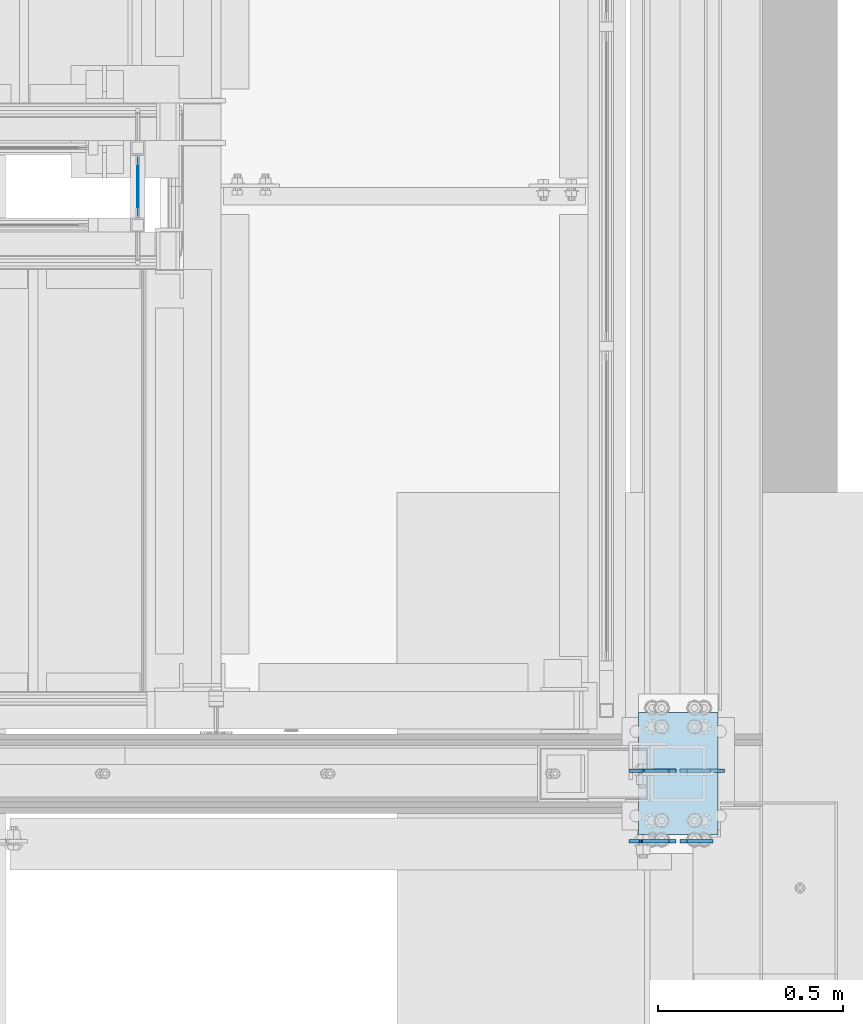
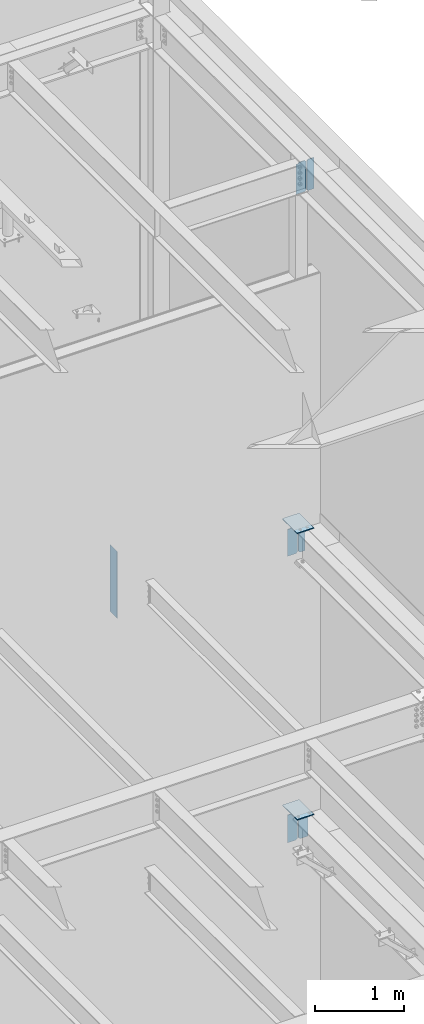
# One storey, part 1098 of 1179: 9 plates, 6 elements without a shape of their own.
"""IFC2X3 building model written with IfcOpenShell, lengths in millimetres."""

from ifc_helpers import new_model, si_unit, frame, origin_with_axes, place, context, subcontext, project, spatial, faceted_brep, material, type_object, element, aggregate, save


model = new_model("IFC2X3")

# Units and contexts
model_context = context("Model", 3, precision=1e-05, world=origin_with_axes())
body_context = subcontext(model_context, "Body", "Model", "MODEL_VIEW")
ifc_project = project(units=[si_unit("LENGTHUNIT", "METRE", prefix="MILLI"), si_unit("AREAUNIT", "SQUARE_METRE"), si_unit("VOLUMEUNIT", "CUBIC_METRE"), si_unit("MASSUNIT", "GRAM", prefix="KILO"), si_unit("TIMEUNIT", "SECOND"), si_unit("PLANEANGLEUNIT", "RADIAN"), si_unit("SOLIDANGLEUNIT", "STERADIAN"), si_unit("THERMODYNAMICTEMPERATUREUNIT", "DEGREE_CELSIUS"), si_unit("LUMINOUSINTENSITYUNIT", "LUMEN")], contexts=[model_context])

# Site, building, storey
site_placement = place(None, origin_with_axes())
site = spatial("IfcSite", under=ifc_project, at=site_placement, CompositionType="ELEMENT")
building_placement = place(site_placement, origin_with_axes())
building = spatial("IfcBuilding", under=site, at=building_placement, Name="Undefined", CompositionType="ELEMENT")
storey_placement = place(building_placement, origin_with_axes())
storey = spatial("IfcBuildingStorey", under=building, at=storey_placement, Name="Undefined", CompositionType="ELEMENT", Elevation=0.0)

# Assembly, plate
assembly_1_placement = place(storey_placement, origin_with_axes())
assembly_1 = element("IfcElementAssembly", 1, at=assembly_1_placement, inside=storey, Name="BEAM", AssemblyPlace="NOTDEFINED", PredefinedType="RIGID_FRAME")
ifc_material_1 = material(Name="STEEL/A36")
plate_type_1 = type_object("IfcPlateType", PredefinedType="NOTDEFINED")
plate_1_placement = place(assembly_1_placement, frame((24302.24375, 37993.6379999161, 7616.825), z_axis=(0.0, 0.0, 1.0), x_axis=(-1.0, 0.0, 0.0)))
plate_1 = element("IfcPlate", 2, at=plate_1_placement, type_object=plate_type_1, material=ifc_material_1, Name="PLATE", context=body_context, shape_type="Brep", body=[
    faceted_brep([(85.8979799225854, -4.76249999999709, 372.964920291218), (85.8979799225854, 4.76249999999709, 372.964920291218), (84.9312499999978, 4.76249999999709, 377.825), (84.9312499999978, -4.76249999999709, 377.825), (88.6509938230629, -4.76249999999709, 368.844743823064), (88.6509938230629, 4.76249999999709, 368.844743823064), (92.7711702912165, -4.76249999999709, 366.091729922586), (92.7711702912165, 4.76249999999709, 366.091729922586), (97.631249809263, -4.76249999999709, 365.124999999998), (97.631249809263, 4.76249999999709, 365.124999999998), (127.0, -4.76249999999709, 365.124999999998), (127.0, 4.76249999999709, 365.124999999998), (0.0, -4.76249999999709, 358.775000762939), (19.0499992370605, -4.76249999999709, 377.825), (19.0499992370605, 4.76249999999709, 377.825), (0.0, 4.76249999999709, 358.775000762939), (0.0, -4.76250000000073, 19.0499992370605), (0.0, 4.76250000000073, 19.0499992370605), (19.0499992370605, -4.76250000000073, 0.0), (19.0499992370605, 4.76250000000073, 0.0), (127.0, -4.76250000000073, 0.0), (127.0, 4.76250000000073, 0.0)], [[[0, 1, 2, 3]], [[4, 5, 1, 0]], [[6, 7, 5, 4]], [[8, 9, 7, 6]], [[10, 11, 9, 8]], [[12, 13, 14, 15]], [[16, 12, 15, 17]], [[18, 16, 17, 19]], [[20, 18, 19, 21]], [[6, 4, 0, 3, 13, 12, 16, 18, 20, 10, 8]], [[14, 13, 3, 2]], [[21, 19, 17, 15, 14, 2, 1, 5, 7, 9, 11]], [[20, 21, 11, 10]]]),
])

assembly_2_placement = place(storey_placement, origin_with_axes())
assembly_2 = element("IfcElementAssembly", 3, at=assembly_2_placement, inside=storey, Name="BEAM", AssemblyPlace="NOTDEFINED", PredefinedType="RIGID_FRAME")
plate_2_placement = place(assembly_2_placement, frame((24302.24375, 37993.6379999161, 3703.6375), z_axis=(0.0, 0.0, 1.0), x_axis=(-1.0, 0.0, 0.0)))
plate_2 = element("IfcPlate", 4, at=plate_2_placement, type_object=plate_type_1, material=ifc_material_1, Name="PLATE", context=body_context, shape_type="Brep", body=[
    faceted_brep([(0.0, -4.76250000000073, 22.2250003814697), (0.0, -4.76249999999709, 355.600011825562), (0.0, 4.76249999999709, 355.600011825562), (0.0, 4.76250000000073, 22.2250003814697), (22.2250003814697, -4.76249999999709, 377.825012207031), (22.2250003814697, 4.76249999999709, 377.825012207031), (127.0, -4.76249999999709, 377.825), (127.0, 4.76249999999709, 377.825), (127.0, -4.76250000000073, 0.0), (127.0, 4.76250000000073, 0.0), (22.2250003814697, -4.76250000000073, 0.0), (22.2250003814697, 4.76250000000073, 0.0)], [[[0, 1, 2, 3]], [[1, 4, 5, 2]], [[4, 6, 7, 5]], [[6, 8, 9, 7]], [[8, 10, 11, 9]], [[10, 0, 3, 11]], [[5, 7, 9, 11, 3, 2]], [[10, 8, 6, 4, 1, 0]]]),
])

assembly_3_placement = place(storey_placement, origin_with_axes())
assembly_3 = element("IfcElementAssembly", 5, at=assembly_3_placement, inside=storey, Name="BEAM", AssemblyPlace="NOTDEFINED", PredefinedType="RIGID_FRAME")
plate_3_placement = place(assembly_3_placement, frame((24302.24375, 37803.1379999161, 12673.0125), z_axis=(0.0, 0.0, 1.0), x_axis=(-1.0, 0.0, 0.0)))
plate_3 = element("IfcPlate", 6, at=plate_3_placement, type_object=plate_type_1, material=ifc_material_1, Name="PLATE", context=body_context, shape_type="Brep", body=[
    faceted_brep([(91.28125, -4.76250000000073, 425.450000000001), (91.28125, -4.76250000000073, 420.687499809264), (91.28125, 4.76250000000073, 420.687499809264), (91.28125, 4.76250000000073, 425.450000000001), (92.2479799225912, -4.76250000000073, 415.827420291219), (92.2479799225912, 4.76250000000073, 415.827420291219), (95.0009938230651, -4.76250000000073, 411.707243823065), (95.0009938230651, 4.76250000000073, 411.707243823065), (99.1211702912187, -4.76250000000073, 408.954229922587), (99.1211702912187, 4.76250000000073, 408.954229922587), (103.981249809265, -4.76250000000073, 407.987499999999), (103.981249809265, 4.76250000000073, 407.987499999999), (126.999999992826, -4.76249999999709, 407.9875), (127.0, 4.76249999999709, 407.9875), (0.0, -4.76249999999709, 406.400000762939), (19.0499992370605, -4.76249999999709, 425.45), (19.0499992370605, 4.76249999999709, 425.45), (0.0, 4.76249999999709, 406.400000762939), (0.0, -4.76250000000073, 19.0499992370605), (0.0, 4.76250000000073, 19.0499992370605), (19.0499992370605, -4.76250000000073, 0.0), (19.0499992370605, 4.76250000000073, 0.0), (127.0, -4.76250000000073, 0.0), (127.0, 4.76250000000073, 0.0)], [[[0, 1, 2, 3]], [[4, 5, 2, 1]], [[6, 7, 5, 4]], [[8, 9, 7, 6]], [[10, 11, 9, 8]], [[12, 13, 11, 10]], [[14, 15, 16, 17]], [[18, 14, 17, 19]], [[20, 18, 19, 21]], [[22, 20, 21, 23]], [[8, 6, 4, 1, 0, 15, 14, 18, 20, 22, 12, 10]], [[16, 15, 0, 3]], [[23, 21, 19, 17, 16, 3, 2, 5, 7, 9, 11, 13]], [[22, 23, 13, 12]]]),
])

assembly_4_placement = place(storey_placement, origin_with_axes())
assembly_4 = element("IfcElementAssembly", 7, at=assembly_4_placement, inside=storey, Name="GUARDRAIL", AssemblyPlace="NOTDEFINED", PredefinedType="RIGID_FRAME")
ifc_material_2 = material(Name="STEEL/BUY-OUT")
plate_type_2 = type_object("IfcPlateType", PredefinedType="NOTDEFINED")
plate_4_placement = place(assembly_4_placement, frame((22844.1248872972, 39655.7500007675, 7232.64999988332), z_axis=(0.0, 0.0, -1.0), x_axis=(0.0, -1.0, 0.0)))
plate_4 = element("IfcPlate", 8, at=plate_4_placement, type_object=plate_type_2, material=ifc_material_2, Name="PERFORATED_PANEL", context=body_context, shape_type="Brep", body=[
    faceted_brep([(0.0, -0.794000000001688, 0.0), (0.0, -0.794000000001688, 912.454389206332), (0.0, 0.794000000001688, 912.454389206332), (0.0, 0.794000000001688, 0.0), (158.750001443463, -0.794000000001688, 912.454388466535), (158.750001443463, 0.794000000001688, 912.454388466535), (158.750001551343, -0.794000000001688, 2.72848410531878e-12), (158.750001551343, 0.794000000001688, 2.72848410531878e-12)], [[[0, 1, 2, 3]], [[1, 4, 5, 2]], [[4, 6, 7, 5]], [[6, 0, 3, 7]], [[5, 7, 3, 2]], [[6, 4, 1, 0]]]),
])
aggregate(assembly_4, [plate_4])

# Plate
plate_type_3 = type_object("IfcPlateType", PredefinedType="NOTDEFINED")
plate_5_placement = place(assembly_3_placement, frame((24313.35625, 37803.1379999161, 12673.0125), z_axis=(0.0, 0.0, 1.0), x_axis=(1.0, 0.0, 0.0)))
plate_5 = element("IfcPlate", 9, at=plate_5_placement, type_object=plate_type_3, material=ifc_material_1, Name="PLATE", context=body_context, shape_type="Brep", body=[
    faceted_brep([(0.0, -4.76250000000073, 19.0499992370605), (0.0, -4.76249999999709, 406.400000762939), (0.0, 4.76249999999709, 406.400000762939), (0.0, 4.76250000000073, 19.0499992370605), (19.0499992370605, -4.76249999999709, 425.45), (19.0499992370605, 4.76249999999709, 425.45), (88.9000015258789, -4.76250000000073, 425.450012207031), (88.9000015258789, 4.76250000000073, 425.450012207031), (88.8999999999996, -4.76250000000005, 0.0), (88.8999999999996, 4.76250000000005, 0.0), (19.0499992370605, -4.76250000000073, 0.0), (19.0499992370605, 4.76250000000073, 0.0)], [[[0, 1, 2, 3]], [[1, 4, 5, 2]], [[4, 6, 7, 5]], [[6, 8, 9, 7]], [[8, 10, 11, 9]], [[10, 0, 3, 11]], [[5, 7, 9, 11, 3, 2]], [[10, 8, 6, 4, 1, 0]]]),
])

aggregate(assembly_3, [plate_5, plate_3])

plate_type_4 = type_object("IfcPlateType", PredefinedType="NOTDEFINED")
plate_6_placement = place(assembly_1_placement, frame((24313.35625, 37993.6379999161, 7616.825), z_axis=(0.0, 0.0, 1.0), x_axis=(1.0, 0.0, 0.0)))
plate_6 = element("IfcPlate", 10, at=plate_6_placement, type_object=plate_type_4, material=ifc_material_1, Name="PLATE", context=body_context, shape_type="Brep", body=[
    faceted_brep([(0.0, -4.76250000000073, 19.0499992370605), (0.0, -4.76249999999709, 358.775000762939), (0.0, 4.76249999999709, 358.775000762939), (0.0, 4.76250000000073, 19.0499992370605), (19.0499992370605, -4.76249999999709, 377.825), (19.0499992370605, 4.76249999999709, 377.825), (82.5500030517578, -4.76249999999709, 377.825012207031), (82.5500030517578, 4.76249999999709, 377.825012207031), (82.5500030517578, -4.76249999999982, 0.0), (82.5500030517578, 4.76249999999982, 0.0), (19.0499992370605, -4.76250000000073, 0.0), (19.0499992370605, 4.76250000000073, 0.0)], [[[0, 1, 2, 3]], [[1, 4, 5, 2]], [[4, 6, 7, 5]], [[6, 8, 9, 7]], [[8, 10, 11, 9]], [[10, 0, 3, 11]], [[5, 7, 9, 11, 3, 2]], [[10, 8, 6, 4, 1, 0]]]),
])

aggregate(assembly_1, [plate_6, plate_1])

# Assembly, plate
assembly_5_placement = place(storey_placement, origin_with_axes())
assembly_5 = element("IfcElementAssembly", 11, at=assembly_5_placement, inside=storey, Name="COLUMN", AssemblyPlace="NOTDEFINED", PredefinedType="RIGID_FRAME")
plate_type_5 = type_object("IfcPlateType", PredefinedType="NOTDEFINED")
plate_7_placement = place(assembly_5_placement, frame((24199.85, 37820.6, 8020.05), z_axis=(0.0, 1.0, 0.0), x_axis=(1.0, 0.0, 0.0)))
plate_7 = element("IfcPlate", 12, at=plate_7_placement, type_object=plate_type_5, material=ifc_material_1, Name="PLATE", context=body_context, shape_type="Brep", body=[
    faceted_brep([(0.0, -6.34999999999854, 0.0), (0.0, -6.35000000000036, 330.200012207031), (0.0, 6.35000000000036, 330.200012207031), (0.0, 6.34999999999854, 0.0), (215.899993896484, -6.35000000000036, 330.200012207031), (215.899993896484, 6.35000000000036, 330.200012207031), (215.899993896484, -6.35000000000036, 0.0), (215.899993896484, 6.35000000000036, 0.0)], [[[0, 1, 2, 3]], [[1, 4, 5, 2]], [[4, 6, 7, 5]], [[6, 0, 3, 7]], [[5, 7, 3, 2]], [[6, 4, 1, 0]]]),
])
aggregate(assembly_5, [plate_7])

assembly_6_placement = place(storey_placement, origin_with_axes())
assembly_6 = element("IfcElementAssembly", 13, at=assembly_6_placement, inside=storey, Name="COLUMN", AssemblyPlace="NOTDEFINED", PredefinedType="RIGID_FRAME")
plate_8_placement = place(assembly_6_placement, frame((24199.85, 37820.6, 4108.45), z_axis=(0.0, 1.0, 0.0), x_axis=(1.0, 0.0, 0.0)))
plate_8 = element("IfcPlate", 14, at=plate_8_placement, type_object=plate_type_5, material=ifc_material_1, Name="PLATE", context=body_context, shape_type="Brep", body=[
    faceted_brep([(0.0, -6.34999999999854, 0.0), (0.0, -6.35000000000036, 330.200012207031), (0.0, 6.35000000000036, 330.200012207031), (0.0, 6.34999999999854, 0.0), (215.899993896484, -6.35000000000036, 330.200012207031), (215.899993896484, 6.35000000000036, 330.200012207031), (215.899993896484, -6.35000000000036, 0.0), (215.899993896484, 6.35000000000036, 0.0)], [[[0, 1, 2, 3]], [[1, 4, 5, 2]], [[4, 6, 7, 5]], [[6, 0, 3, 7]], [[5, 7, 3, 2]], [[6, 4, 1, 0]]]),
])
aggregate(assembly_6, [plate_8])

# Plate
plate_type_6 = type_object("IfcPlateType", PredefinedType="NOTDEFINED")
plate_9_placement = place(assembly_2_placement, frame((24313.35625, 37993.6379999161, 3703.6375), z_axis=(0.0, 0.0, 1.0), x_axis=(1.0, 0.0, 0.0)))
plate_9 = element("IfcPlate", 15, at=plate_9_placement, type_object=plate_type_6, material=ifc_material_1, Name="PLATE", context=body_context, shape_type="Brep", body=[
    faceted_brep([(0.0, -4.76250000000073, 22.2250003814697), (0.0, -4.76249999999709, 355.600011825562), (0.0, 4.76249999999709, 355.600011825562), (0.0, 4.76250000000073, 22.2250003814697), (22.2250003814697, -4.76249999999709, 377.825012207031), (22.2250003814697, 4.76249999999709, 377.825012207031), (120.650001525879, -4.76249999999709, 377.825012207031), (120.650001525879, 4.76249999999709, 377.825012207031), (120.650001525879, -4.76249999999709, 0.0), (120.650001525879, 4.76249999999709, 0.0), (22.2250003814697, -4.76250000000073, 0.0), (22.2250003814697, 4.76250000000073, 0.0)], [[[0, 1, 2, 3]], [[1, 4, 5, 2]], [[4, 6, 7, 5]], [[6, 8, 9, 7]], [[8, 10, 11, 9]], [[10, 0, 3, 11]], [[5, 7, 9, 11, 3, 2]], [[10, 8, 6, 4, 1, 0]]]),
])

aggregate(assembly_2, [plate_9, plate_2])

save(model, "model.ifc")
